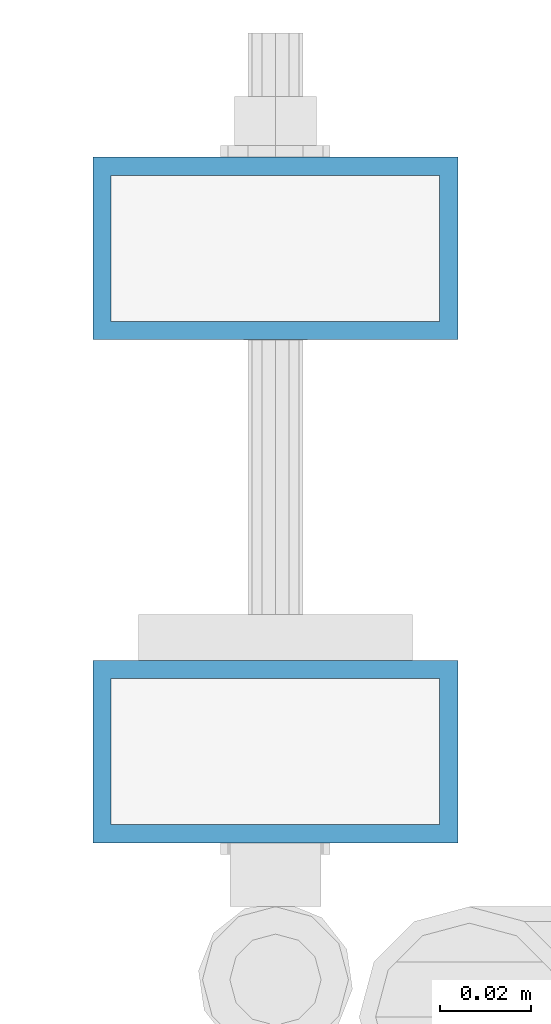
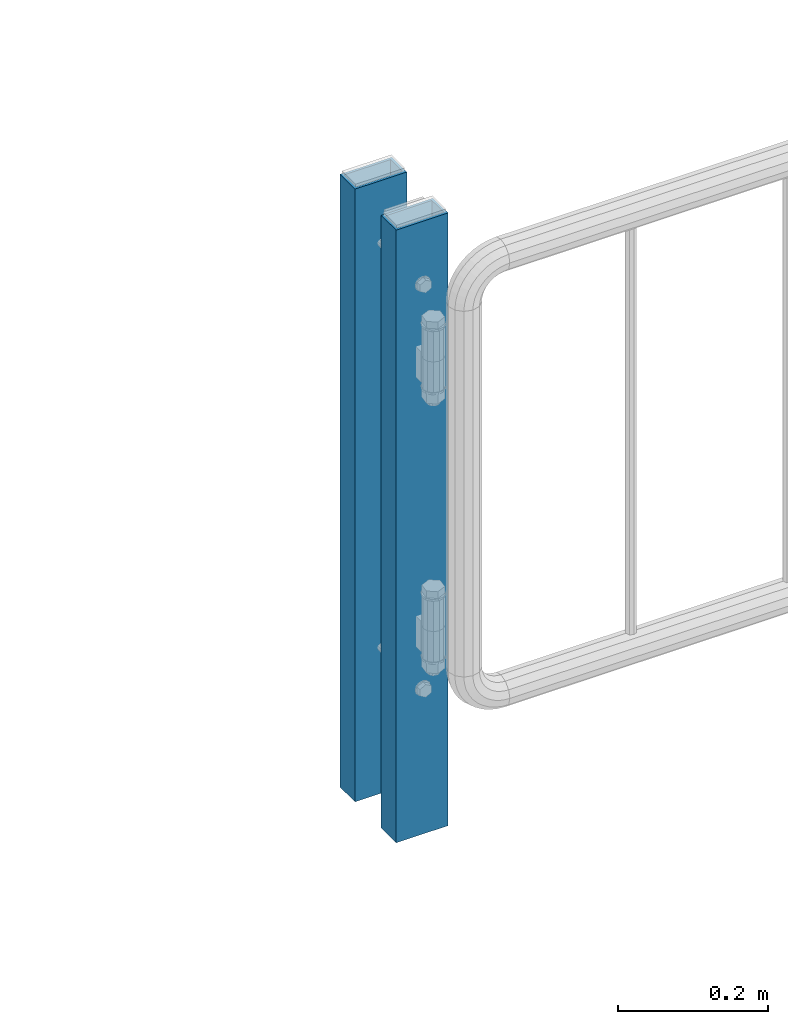
# One storey, part 65 of 247: 2 columns.
"""IFC2X3 building model written with IfcOpenShell, lengths in millimetres."""

import ifcopenshell
import ifcopenshell.guid

model = None  # the IFC model being written
_history = None  # IfcOwnerHistory: only IFC2X3 demands one
_inside = {}  # id of a spatial element -> (the spatial element, [elements in it])
_under = {}  # id of a project, library or spatial element -> (it, [spatial elements below it])
_declared = {}  # id of a project -> (the project, [libraries it declares])
_typed = {}  # id of a type object -> (the type object, [elements of that type])
_made_of = {}  # id of a material, layer set ... -> (it, [elements and type objects made of it])


def new_model(schema):
    """Start an empty IFC model of exactly this schema.

    Asked for "IFC4X3", IfcOpenShell would pick the latest addendum, in which some entities
    have other attributes; the version numbers below select the first issue.
    IFC2X3 requires an IfcOwnerHistory on every rooted entity: one is made here for all.
    """
    global model, _history
    if schema == "IFC4X3":
        model = ifcopenshell.file(schema_version=(4, 3, 0, 0))
    else:
        model = ifcopenshell.file(schema=schema)
    _inside.clear()
    _under.clear()
    _declared.clear()
    _typed.clear()
    _made_of.clear()
    _history = None
    if model.schema == "IFC2X3":
        org = make("IfcOrganization", Name="unknown")
        user = make(
            "IfcPersonAndOrganization",
            ThePerson=make("IfcPerson", FamilyName="unknown"),
            TheOrganization=org,
        )
        app = make(
            "IfcApplication",
            ApplicationDeveloper=org,
            Version="unknown",
            ApplicationFullName="unknown",
            ApplicationIdentifier="unknown",
        )
        _history = make(
            "IfcOwnerHistory",
            OwningUser=user,
            OwningApplication=app,
            ChangeAction="ADDED",
            CreationDate=0,
        )
    return model


def make(cls, **values):
    """One entity of the class cls with the attributes given. An attribute that is None is left unset."""
    return model.create_entity(
        cls, **{name: value for name, value in values.items() if value is not None}
    )


def rooted(cls, **values):
    """An entity with a GlobalId (a new one), such as an element, a storey or a relation."""
    return make(cls, GlobalId=ifcopenshell.guid.new(), OwnerHistory=_history, **values)


def si_unit(unit_type, name, prefix=None):
    """IfcSIUnit, for example si_unit("LENGTHUNIT", "METRE", prefix="MILLI")."""
    return make("IfcSIUnit", UnitType=unit_type, Prefix=prefix, Name=name)


def assignment(units):
    """IfcUnitAssignment: the units of a project."""
    return None if units is None else make("IfcUnitAssignment", Units=units)


def point(xyz):
    """IfcCartesianPoint."""
    return None if xyz is None else make("IfcCartesianPoint", Coordinates=xyz)


def direction(xyz):
    """IfcDirection."""
    return None if xyz is None else make("IfcDirection", DirectionRatios=xyz)


def frame(location, z_axis=None, x_axis=None):
    """IfcAxis2Placement3D, a coordinate frame: its origin and axes. An axis left out is left unset."""
    return make(
        "IfcAxis2Placement3D",
        Location=point(location),
        Axis=direction(z_axis),
        RefDirection=direction(x_axis),
    )


def origin_with_axes():
    """The frame at (0, 0, 0) with the z axis (0, 0, 1) and the x axis (1, 0, 0) written out."""
    return frame((0.0, 0.0, 0.0), z_axis=(0.0, 0.0, 1.0), x_axis=(1.0, 0.0, 0.0))


def place(relative_to, where):
    """IfcLocalPlacement: puts the frame where relative to a parent placement (None: the world)."""
    return make(
        "IfcLocalPlacement", PlacementRelTo=relative_to, RelativePlacement=where
    )


def context(
    kind, dimensions, precision=None, world=None, true_north=None, identifier=None
):
    """IfcGeometricRepresentationContext, for example the 3D "Model" context."""
    return make(
        "IfcGeometricRepresentationContext",
        ContextIdentifier=identifier,
        ContextType=kind,
        CoordinateSpaceDimension=dimensions,
        Precision=precision,
        WorldCoordinateSystem=world,
        TrueNorth=true_north,
    )


def subcontext(parent, identifier, kind, view, scale=None):
    """IfcGeometricRepresentationSubContext, for example "Body" below "Model"."""
    return make(
        "IfcGeometricRepresentationSubContext",
        ContextIdentifier=identifier,
        ContextType=kind,
        ParentContext=parent,
        TargetScale=scale,
        TargetView=view,
    )


def project(units=None, contexts=None):
    """IfcProject with its units and contexts."""
    return rooted(
        "IfcProject",
        Name="project",
        RepresentationContexts=contexts,
        UnitsInContext=assignment(units),
    )


def spatial(cls, under=None, at=None, **own):
    """A site, building, storey or space (cls), placed at a placement, below another one or the project."""
    s = rooted(cls, ObjectPlacement=at, **own)
    if under is not None:
        _under.setdefault(under.id(), (under, []))[1].append(s)
    return s


def faces_of(points, faces, orient=None, outer=None):
    """IfcFace entities. A face is a list of loops; a loop is a list of indices into points, from 0.

    orient and outer hold one flag for each loop. By default every Orientation is true, the
    first loop of a face is its IfcFaceOuterBound and the others are IfcFaceBound.
    """
    made = []
    for i, loops in enumerate(faces):
        bounds = []
        for j, loop in enumerate(loops):
            is_outer = j == 0 if outer is None else outer[i][j]
            bounds.append(
                make(
                    "IfcFaceOuterBound" if is_outer else "IfcFaceBound",
                    Bound=make("IfcPolyLoop", Polygon=[points[k] for k in loop]),
                    Orientation=True if orient is None else orient[i][j],
                )
            )
        made.append(make("IfcFace", Bounds=bounds))
    return made


def faceted_brep(points, faces, orient=None, outer=None, voids=None):
    """IfcFacetedBrep: a solid bounded by flat faces; with voids (closed shells), ...WithVoids."""
    shared = [point(p) for p in points]
    hull = make("IfcClosedShell", CfsFaces=faces_of(shared, faces, orient, outer))
    if voids is None:
        return make("IfcFacetedBrep", Outer=hull)
    return make(
        "IfcFacetedBrepWithVoids",
        Outer=hull,
        Voids=[
            make(cls, CfsFaces=faces_of(shared, fs, o, b)) for cls, fs, o, b in voids
        ],
    )


def shape(context_of_items, identifier, shape_type, items):
    """IfcShapeRepresentation: the items that make up one representation, for example the "Body"."""
    return make(
        "IfcShapeRepresentation",
        ContextOfItems=context_of_items,
        RepresentationIdentifier=identifier,
        RepresentationType=shape_type,
        Items=items,
    )


def material(Name=None, Category=None):
    """IfcMaterial."""
    return make("IfcMaterial", Name=Name, Category=Category)


def made_of(thing, what):
    """Note that an element or type object is made of a material, layer set ...; save() writes the relation."""
    if what is not None:
        _made_of.setdefault(what.id(), (what, []))[1].append(thing)
    return thing


def type_object(cls, material=None, **own):
    """A type object (cls), such as IfcWallType, which elements share."""
    return made_of(rooted(cls, **own), material)


def element(
    cls,
    number,
    at=None,
    inside=None,
    cuts=None,
    type_object=None,
    material=None,
    context=None,
    identifier="Body",
    shape_type=None,
    held_by="IfcProductDefinitionShape",
    body=None,
    shapes=None,
    **own,
):
    """One element of the class cls, such as IfcWall. Its Tag is "e" and its number.

    at: its placement. inside: the storey or other place that contains it. cuts: it is an
    opening in that element (IfcRelVoidsElement). A single representation is given by context,
    identifier, shape_type and body (its items); several are given by shapes. held_by: the class
    of the entity that holds the representations. save() writes the other relations.
    """
    e = rooted(cls, Tag="e%d" % number, ObjectPlacement=at, **own)
    if body is not None:
        shapes = [shape(context, identifier, shape_type, body)]
    if shapes is not None:
        e.Representation = make(held_by, Representations=shapes)
    if inside is not None:
        _inside.setdefault(inside.id(), (inside, []))[1].append(e)
    if cuts is not None:
        rooted(
            "IfcRelVoidsElement", RelatingBuildingElement=cuts, RelatedOpeningElement=e
        )
    if type_object is not None:
        _typed.setdefault(type_object.id(), (type_object, []))[1].append(e)
    return made_of(e, material)


def aggregate(whole, parts):
    """IfcRelAggregates: a whole, such as a stair, and the parts it consists of."""
    return rooted("IfcRelAggregates", RelatingObject=whole, RelatedObjects=parts)


def save(model, path):
    """Write the relations noted so far, then the file.

    IfcRelAggregates (storeys below a building ...), IfcRelContainedInSpatialStructure (elements
    in a storey), IfcRelDefinesByType, IfcRelAssociatesMaterial and IfcRelDeclares: one each for
    every whole, place, type object, material and project.
    """
    for whole, parts in _under.values():
        aggregate(whole, parts)
    for where, things in _inside.values():
        rooted(
            "IfcRelContainedInSpatialStructure",
            RelatedElements=things,
            RelatingStructure=where,
        )
    for kind, things in _typed.values():
        rooted("IfcRelDefinesByType", RelatedObjects=things, RelatingType=kind)
    for what, things in _made_of.values():
        rooted("IfcRelAssociatesMaterial", RelatedObjects=things, RelatingMaterial=what)
    for by, libraries in _declared.values():
        rooted("IfcRelDeclares", RelatingContext=by, RelatedDefinitions=libraries)
    model.write(path)


model = new_model("IFC2X3")

# Units and contexts
model_context = context("Model", 3, precision=1e-05, world=origin_with_axes())
body_context = subcontext(model_context, "Body", "Model", "MODEL_VIEW")
ifc_project = project(units=[si_unit("LENGTHUNIT", "METRE", prefix="MILLI"), si_unit("AREAUNIT", "SQUARE_METRE"), si_unit("VOLUMEUNIT", "CUBIC_METRE"), si_unit("MASSUNIT", "GRAM", prefix="KILO"), si_unit("TIMEUNIT", "SECOND"), si_unit("PLANEANGLEUNIT", "RADIAN"), si_unit("SOLIDANGLEUNIT", "STERADIAN"), si_unit("THERMODYNAMICTEMPERATUREUNIT", "DEGREE_CELSIUS"), si_unit("LUMINOUSINTENSITYUNIT", "LUMEN")], contexts=[model_context])

# Site, building, storey
site_placement = place(None, origin_with_axes())
site = spatial("IfcSite", under=ifc_project, at=site_placement, CompositionType="ELEMENT")
building_placement = place(site_placement, origin_with_axes())
building = spatial("IfcBuilding", under=site, at=building_placement, Name="Standard", CompositionType="ELEMENT")
storey_placement = place(building_placement, origin_with_axes())
storey = spatial("IfcBuildingStorey", under=building, at=storey_placement, Name="Undefined", CompositionType="ELEMENT", Elevation=0.0)

# Columns
ifc_material = material()
column_type = type_object("IfcColumnType", PredefinedType="NOTDEFINED")
for number, where, z_axis, x_axis in (
    (1, (26855.7462613762, 6110.30337247849, 6.54446186132418e-06), (-1.0, 0.0, 0.0), (0.0, 0.0, 1.0)),
    (2, (26855.7462613762, 6000.0033724785, 6.54446186132418e-06), (-1.0, 0.0, 0.0), (0.0, 0.0, 1.0)),
):
    element("IfcColumn", number, at=place(storey_placement, frame(where, z_axis=z_axis, x_axis=x_axis)), inside=storey, type_object=column_type, material=ifc_material, context=body_context, shape_type="Brep", body=[
        faceted_brep([(0.0, 16.0, -36.0), (0.0, -16.0, -36.0), (1000.0, -16.0, -36.0), (1000.0, 16.0, -36.0), (0.0, -16.0, 36.0), (1000.0, -16.0, 36.0), (0.0, 16.0, 36.0), (1000.0, 16.0, 36.0), (0.0, 20.0, -40.0), (0.0, 20.0, 40.0), (1000.0, 20.0, 40.0), (1000.0, 20.0, -40.0), (0.0, -20.0, 40.0), (1000.0, -20.0, 40.0), (0.0, -20.0, -40.0), (1000.0, -20.0, -40.0)], [[[0, 1, 2, 3]], [[1, 4, 5, 2]], [[4, 6, 7, 5]], [[6, 0, 3, 7]], [[8, 9, 10, 11]], [[9, 12, 13, 10]], [[12, 14, 15, 13]], [[14, 8, 11, 15]], [[13, 15, 11, 10], [5, 7, 3, 2]], [[14, 12, 9, 8], [6, 4, 1, 0]]]),
    ])

save(model, "model.ifc")
